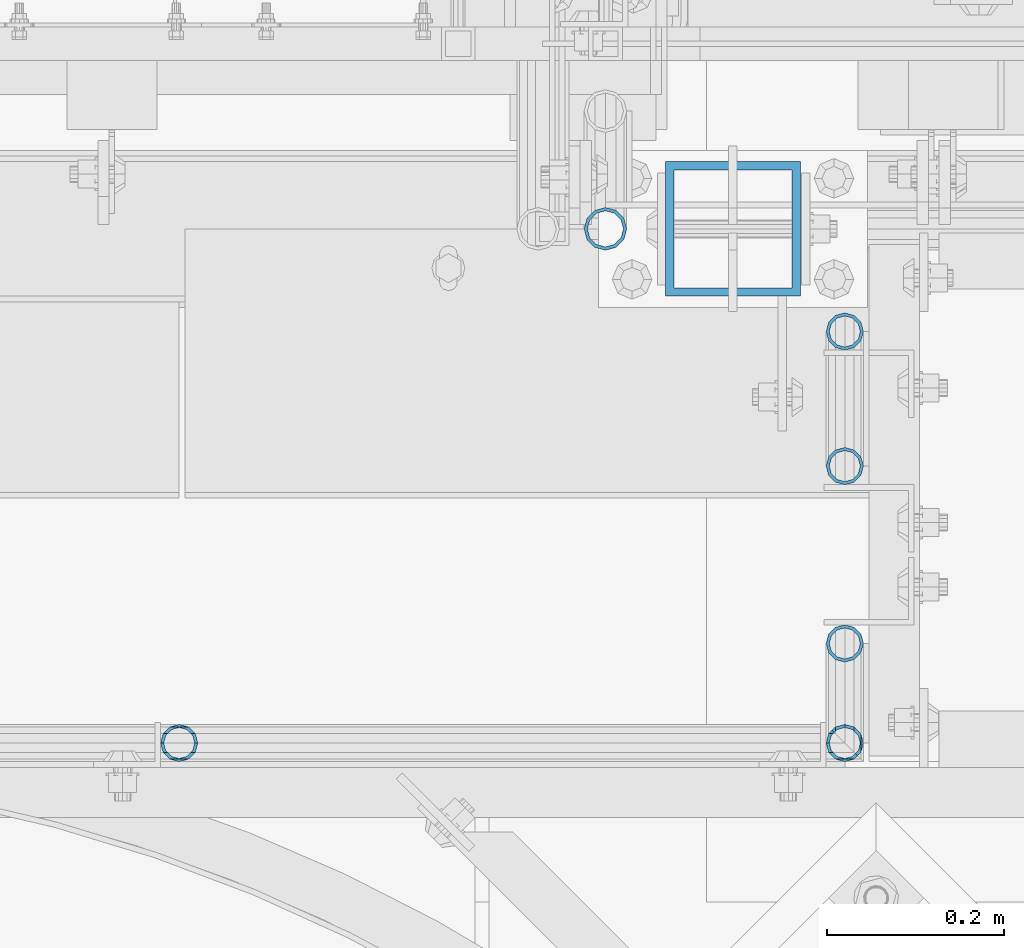
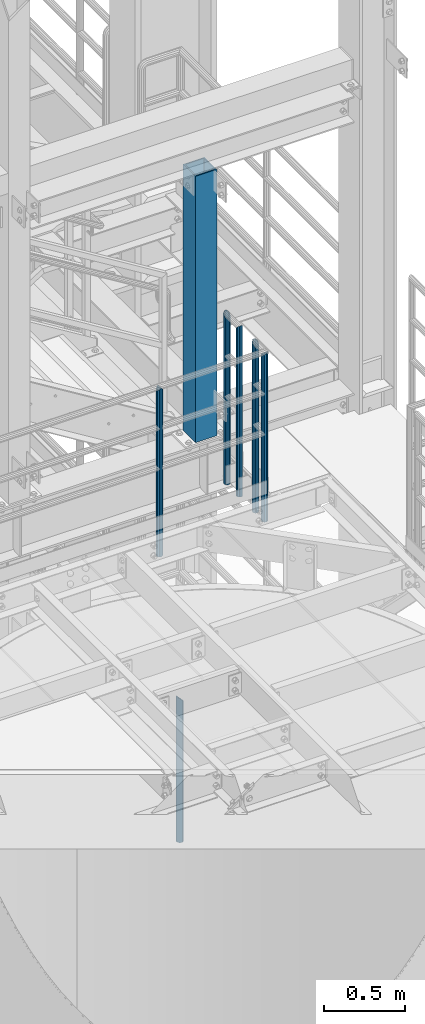
# One storey, part 584 of 1876: 7 columns, 4 elements without a shape of their own.
"""IFC2X3 building model written with IfcOpenShell, lengths in millimetres."""

from ifc_helpers import new_model, si_unit, frame, origin_with_axes, place, context, subcontext, project, spatial, faceted_brep, material, type_object, element, aggregate, save


model = new_model("IFC2X3")

# Units and contexts
model_context = context("Model", 3, precision=1e-05, world=origin_with_axes())
body_context = subcontext(model_context, "Body", "Model", "MODEL_VIEW")
ifc_project = project(units=[si_unit("LENGTHUNIT", "METRE", prefix="MILLI"), si_unit("AREAUNIT", "SQUARE_METRE"), si_unit("VOLUMEUNIT", "CUBIC_METRE"), si_unit("MASSUNIT", "GRAM", prefix="KILO"), si_unit("TIMEUNIT", "SECOND"), si_unit("PLANEANGLEUNIT", "RADIAN"), si_unit("SOLIDANGLEUNIT", "STERADIAN"), si_unit("THERMODYNAMICTEMPERATUREUNIT", "DEGREE_CELSIUS"), si_unit("LUMINOUSINTENSITYUNIT", "LUMEN")], contexts=[model_context])

# Site, building, storey
site_placement = place(None, origin_with_axes())
site = spatial("IfcSite", under=ifc_project, at=site_placement, CompositionType="ELEMENT")
building_placement = place(site_placement, origin_with_axes())
building = spatial("IfcBuilding", under=site, at=building_placement, Name="Undefined", CompositionType="ELEMENT")
storey_placement = place(building_placement, origin_with_axes())
storey = spatial("IfcBuildingStorey", under=building, at=storey_placement, Name="Undefined", CompositionType="ELEMENT", Elevation=0.0)

# Assembly, columns
assembly_1_placement = place(storey_placement, origin_with_axes())
assembly_1 = element("IfcElementAssembly", 1, at=assembly_1_placement, inside=storey, Name="RAIL", AssemblyPlace="NOTDEFINED", PredefinedType="RIGID_FRAME")
ifc_material_1 = material()
column_type_1 = type_object("IfcColumnType", Name="PIPE1-1/4STD", PredefinedType="NOTDEFINED")
column_1_placement = place(assembly_1_placement, frame((6544.818, -7380.60115429563, 7813.675), z_axis=(0.0, 1.0, 0.0), x_axis=(0.0, 0.0, 1.0)))
column_1 = element("IfcColumn", 2, at=column_1_placement, type_object=column_type_1, material=ifc_material_1, Name="POST", ObjectType="PIPE1-1/4STD", context=body_context, shape_type="Brep", body=[
    faceted_brep([(0.0, -17.5259999999998, 0.0), (0.0, -15.1779612267264, 8.76300000000083), (1267.58699999999, -15.1779612267264, 8.76299999999992), (1276.35000231344, -17.5259999999998, 0.0), (0.0, -8.76299999999992, 15.1779612267255), (1261.17203877327, -8.76299999999992, 15.1779612267264), (0.0, 0.0, 17.5259999999998), (1258.82399999999, 0.0, 17.5259999999998), (0.0, 8.76299999999992, 15.1779612267255), (1261.17203877327, 8.76299999999992, 15.1779612267264), (0.0, 15.1779612267264, 8.76300000000083), (1267.58699999999, 15.1779612267264, 8.76299999999992), (0.0, 17.5259999999998, 0.0), (1276.34999768657, 17.5259999999998, 0.0), (0.0, 15.1779612267264, -8.76300000000083), (1285.11299999999, 15.1779612267264, -8.76299999999992), (0.0, 8.76299999999992, -15.1779612267255), (1291.52796122672, 8.76299999999992, -15.1779612267264), (0.0, 0.0, -17.5259999999998), (1293.87599999999, 0.0, -17.5259999999998), (0.0, -8.76299999999992, -15.1779612267255), (1291.52796122672, -8.76299999999992, -15.1779612267264), (0.0, -15.1779612267264, -8.76300000000083), (1285.11299999999, -15.1779612267264, -8.76299999999992), (9.09494701772928e-13, -21.0820000000003, 0.0), (0.0, -18.2575475625836, -10.5409999999993), (1286.89099999999, -18.2575475625836, -10.5410000000002), (1276.35000278283, -21.0820000000003, 0.0), (0.0, -10.5410000000002, -18.2575475625836), (1294.60754756258, -10.5410000000002, -18.2575475625836), (-4.28826751885936e-09, 0.0, -21.0820000000003), (1297.43199999999, 0.0, -21.0820000000003), (0.0, 10.5410000000002, -18.2575475625836), (1294.60754756258, 10.5410000000002, -18.2575475625836), (0.0, 18.2575475625836, -10.5409999999993), (1286.89099999999, 18.2575475625836, -10.5410000000002), (9.09494701772928e-13, 21.0820000000003, 0.0), (1276.35, 21.0820000000003, 0.0), (0.0, 18.2575475625836, 10.5409999999993), (1265.809, 18.2575475625836, 10.5410000000002), (0.0, 10.5410000000002, 18.2575475625836), (1258.09245243742, 10.5410000000002, 18.2575475625836), (0.0, 0.0, 21.0820000000003), (1255.268, 0.0, 21.0820000000003), (0.0, -10.5410000000002, 18.2575475625836), (1258.09245243742, -10.5410000000002, 18.2575475625836), (0.0, -18.2575475625836, 10.5409999999993), (1265.809, -18.2575475625836, 10.5410000000002)], [[[0, 1, 2, 3]], [[1, 4, 5, 2]], [[4, 6, 7, 5]], [[6, 8, 9, 7]], [[8, 10, 11, 9]], [[10, 12, 13, 11]], [[12, 14, 15, 13]], [[14, 16, 17, 15]], [[16, 18, 19, 17]], [[18, 20, 21, 19]], [[20, 22, 23, 21]], [[22, 0, 3, 23]], [[24, 25, 26, 27]], [[25, 28, 29, 26]], [[28, 30, 31, 29]], [[30, 32, 33, 31]], [[32, 34, 35, 33]], [[34, 36, 37, 35]], [[36, 38, 39, 37]], [[38, 40, 41, 39]], [[40, 42, 43, 41]], [[42, 44, 45, 43]], [[44, 46, 47, 45]], [[46, 24, 27, 47]], [[29, 31, 33, 35, 37, 39, 41, 43, 45, 47, 27, 26], [5, 7, 9, 11, 13, 15, 17, 19, 21, 23, 3, 2]], [[46, 44, 42, 40, 38, 36, 34, 32, 30, 28, 25, 24], [22, 20, 18, 16, 14, 12, 10, 8, 6, 4, 1, 0]]]),
])
column_2_placement = place(assembly_1_placement, frame((6544.818, -7228.20115429563, 7813.675), z_axis=(0.0, 1.0, 0.0), x_axis=(0.0, 0.0, 1.0)))
column_2 = element("IfcColumn", 3, at=column_2_placement, type_object=column_type_1, material=ifc_material_1, Name="POST", ObjectType="PIPE1-1/4STD", context=body_context, shape_type="Brep", body=[
    faceted_brep([(0.0, -17.5259999999998, 0.0), (0.0, -15.1779612267264, 8.76300000000083), (1285.11300200349, -15.1779612267264, 8.76299999999992), (1276.35000231344, -17.5259999999998, 0.0), (0.0, -8.76299999999992, 15.1779612267255), (1291.52796238344, -8.76299999999992, 15.1779612267264), (0.0, 0.0, 17.5259999999998), (1293.876, 0.0, 17.5259999999998), (0.0, 8.76299999999992, 15.1779612267255), (1291.52796007001, 8.76299999999992, 15.1779612267264), (0.0, 15.1779612267264, 8.76300000000083), (1285.11299799651, 15.1779612267264, 8.76299999999992), (0.0, 17.5259999999998, 0.0), (1276.34999768657, 17.5259999999998, 0.0), (0.0, 15.1779612267264, -8.76300000000083), (1267.58699799651, 15.1779612267264, -8.76299999999992), (0.0, 8.76299999999992, -15.1779612267255), (1261.17203761656, 8.76299999999992, -15.1779612267264), (0.0, 0.0, -17.5259999999998), (1258.824, 0.0, -17.5259999999998), (0.0, -8.76299999999992, -15.1779612267255), (1261.17203992999, -8.76299999999992, -15.1779612267264), (0.0, -15.1779612267264, -8.76300000000083), (1267.58700200349, -15.1779612267264, -8.76299999999992), (9.09494701772928e-13, -21.0820000000003, 0.0), (0.0, -18.2575475625836, -10.5409999999993), (1265.809, -18.2575475625836, -10.5410000000002), (1276.35000278283, -21.0820000000003, 0.0), (0.0, -10.5410000000002, -18.2575475625836), (1258.09245243742, -10.5410000000002, -18.2575475625836), (-4.28826751885936e-09, 0.0, -21.0820000000003), (1255.268, 0.0, -21.0820000000003), (0.0, 10.5410000000002, -18.2575475625836), (1258.09245243742, 10.5410000000002, -18.2575475625836), (0.0, 18.2575475625836, -10.5409999999993), (1265.809, 18.2575475625836, -10.5410000000002), (9.09494701772928e-13, 21.0820000000003, 0.0), (1276.35, 21.0820000000003, 0.0), (0.0, 18.2575475625836, 10.5409999999993), (1286.89099759001, 18.2575475625836, 10.5410000000002), (0.0, 10.5410000000002, 18.2575475625836), (1294.60754617117, 10.5410000000002, 18.2575475625836), (0.0, 0.0, 21.0820000000003), (1297.432, 0.0, 21.0820000000003), (0.0, -10.5410000000002, 18.2575475625836), (1294.607548954, -10.5410000000002, 18.2575475625836), (0.0, -18.2575475625836, 10.5409999999993), (1286.89100241, -18.2575475625836, 10.5410000000002)], [[[0, 1, 2, 3]], [[1, 4, 5, 2]], [[4, 6, 7, 5]], [[6, 8, 9, 7]], [[8, 10, 11, 9]], [[10, 12, 13, 11]], [[12, 14, 15, 13]], [[14, 16, 17, 15]], [[16, 18, 19, 17]], [[18, 20, 21, 19]], [[20, 22, 23, 21]], [[22, 0, 3, 23]], [[24, 25, 26, 27]], [[25, 28, 29, 26]], [[28, 30, 31, 29]], [[30, 32, 33, 31]], [[32, 34, 35, 33]], [[34, 36, 37, 35]], [[36, 38, 39, 37]], [[38, 40, 41, 39]], [[40, 42, 43, 41]], [[42, 44, 45, 43]], [[44, 46, 47, 45]], [[46, 24, 27, 47]], [[29, 31, 33, 35, 37, 39, 41, 43, 45, 47, 27, 26], [5, 7, 9, 11, 13, 15, 17, 19, 21, 23, 3, 2]], [[46, 44, 42, 40, 38, 36, 34, 32, 30, 28, 25, 24], [22, 20, 18, 16, 14, 12, 10, 8, 6, 4, 1, 0]]]),
])
aggregate(assembly_1, [column_1, column_2])

assembly_2_placement = place(storey_placement, origin_with_axes())
assembly_2 = element("IfcElementAssembly", 4, at=assembly_2_placement, inside=storey, Name="HANDRAIL", AssemblyPlace="NOTDEFINED", PredefinedType="RIGID_FRAME")
column_3_placement = place(assembly_2_placement, frame((6544.818, -7581.41990429563, 7813.675), z_axis=(0.0, 1.0, 0.0), x_axis=(0.0, 0.0, 1.0)))
column_3 = element("IfcColumn", 5, at=column_3_placement, type_object=column_type_1, material=ifc_material_1, Name="POST", ObjectType="PIPE1-1/4STD", context=body_context, shape_type="Brep", body=[
    faceted_brep([(0.0, -17.5259999999998, 0.0), (0.0, -15.1779612267264, 8.76300000000083), (1285.11300200349, -15.1779612267264, 8.76299999999992), (1276.35000231344, -17.5259999999998, 0.0), (0.0, -8.76299999999992, 15.1779612267255), (1291.52796238344, -8.76299999999992, 15.1779612267264), (0.0, 0.0, 17.5259999999998), (1293.876, 0.0, 17.5259999999998), (0.0, 8.76299999999992, 15.1779612267255), (1291.52796007001, 8.76299999999992, 15.1779612267264), (0.0, 15.1779612267264, 8.76300000000083), (1285.11299799651, 15.1779612267264, 8.76299999999992), (0.0, 17.5259999999998, 0.0), (1276.34999768657, 17.5259999999998, 0.0), (0.0, 15.1779612267264, -8.76300000000083), (1267.58699799651, 15.1779612267264, -8.76299999999992), (0.0, 8.76299999999992, -15.1779612267255), (1261.17203761656, 8.76299999999992, -15.1779612267264), (0.0, 0.0, -17.5259999999998), (1258.824, 0.0, -17.5259999999998), (0.0, -8.76299999999992, -15.1779612267255), (1261.17203992999, -8.76299999999992, -15.1779612267264), (0.0, -15.1779612267264, -8.76300000000083), (1267.58700200349, -15.1779612267264, -8.76299999999992), (9.09494701772928e-13, -21.0820000000003, 0.0), (0.0, -18.2575475625836, -10.5409999999993), (1265.809, -18.2575475625836, -10.5410000000002), (1276.35000278283, -21.0820000000003, 0.0), (0.0, -10.5410000000002, -18.2575475625836), (1258.09245243742, -10.5410000000002, -18.2575475625836), (-4.28826751885936e-09, 0.0, -21.0820000000003), (1255.268, 0.0, -21.0820000000003), (0.0, 10.5410000000002, -18.2575475625836), (1258.09245243742, 10.5410000000002, -18.2575475625836), (0.0, 18.2575475625836, -10.5409999999993), (1265.809, 18.2575475625836, -10.5410000000002), (9.09494701772928e-13, 21.0820000000003, 0.0), (1276.35, 21.0820000000003, 0.0), (0.0, 18.2575475625836, 10.5409999999993), (1286.89099759001, 18.2575475625836, 10.5410000000002), (0.0, 10.5410000000002, 18.2575475625836), (1294.60754617117, 10.5410000000002, 18.2575475625836), (0.0, 0.0, 21.0820000000003), (1297.432, 0.0, 21.0820000000003), (0.0, -10.5410000000002, 18.2575475625836), (1294.607548954, -10.5410000000002, 18.2575475625836), (0.0, -18.2575475625836, 10.5409999999993), (1286.89100241, -18.2575475625836, 10.5410000000002)], [[[0, 1, 2, 3]], [[1, 4, 5, 2]], [[4, 6, 7, 5]], [[6, 8, 9, 7]], [[8, 10, 11, 9]], [[10, 12, 13, 11]], [[12, 14, 15, 13]], [[14, 16, 17, 15]], [[16, 18, 19, 17]], [[18, 20, 21, 19]], [[20, 22, 23, 21]], [[22, 0, 3, 23]], [[24, 25, 26, 27]], [[25, 28, 29, 26]], [[28, 30, 31, 29]], [[30, 32, 33, 31]], [[32, 34, 35, 33]], [[34, 36, 37, 35]], [[36, 38, 39, 37]], [[38, 40, 41, 39]], [[40, 42, 43, 41]], [[42, 44, 45, 43]], [[44, 46, 47, 45]], [[46, 24, 27, 47]], [[29, 31, 33, 35, 37, 39, 41, 43, 45, 47, 27, 26], [5, 7, 9, 11, 13, 15, 17, 19, 21, 23, 3, 2]], [[46, 44, 42, 40, 38, 36, 34, 32, 30, 28, 25, 24], [22, 20, 18, 16, 14, 12, 10, 8, 6, 4, 1, 0]]]),
])
column_4_placement = place(assembly_2_placement, frame((6544.818, -7694.13240429563, 7813.675), z_axis=(0.0, 1.0, 0.0), x_axis=(0.0, 0.0, 1.0)))
column_4 = element("IfcColumn", 6, at=column_4_placement, type_object=column_type_1, material=ifc_material_1, Name="POST", ObjectType="PIPE1-1/4STD", context=body_context, shape_type="Brep", body=[
    faceted_brep([(1276.35, 0.0, -21.0820000000003), (1265.809, 10.5410000000002, -18.2575475625836), (1265.809, -10.5410000000002, -18.2575475625836), (1261.95301633583, 14.3969836641645, -14.4015638984183), (1259.5242231679, 11.9681904962363, -11.9727707304901), (1262.72937633681, 8.76299999999992, -15.1779612267255), (1265.07741511008, 0.0, -17.5259999999998), (1262.72937633681, -8.76299999999992, -15.1779612267255), (1258.09245243741, -13.3999612267244, -10.541000000002), (1258.09245243742, -18.2575475625836, -10.5409999999993), (1257.61602877145, -15.1779612267264, -8.76300000000083), (1255.268, -17.5259999999998, 0.0), (1255.268, -21.0820000000003, 0.0), (1257.61604877511, -15.1779612267264, 8.76300000000083), (1258.09245243741, -13.399961226728, 10.5409999999983), (1258.09245243742, -18.2575475625836, 10.5409999999993), (1259.51964293365, -11.9727707304901, 11.9681904962363), (1261.94843610158, -14.4015638984183, 14.3969836641645), (1258.09245243741, -10.5455802342522, 13.3953809924742), (1258.09245243742, -10.5410000000002, 18.2575475625836), (1257.6148115032, -8.76299999999992, 15.1779612267264), (1255.268, 0.0, 17.5259999999998), (1255.268, 0.0, 21.0820000000003), (1257.61726604334, 8.76299999999992, 15.1779612267264), (1258.09245243741, 10.5364197657482, 13.4045414609782), (1258.09245243742, 10.5410000000002, 18.2575475625836), (1276.35, 21.0774197657483, 0.0), (1265.809, 18.2575475625836, 10.5410000000002), (1265.809, 18.2575475625836, -10.5410000000002), (1262.73399389839, 15.1779612267264, 8.76299999999992), (1265.08203267166, 17.5259999999998, 0.0), (1262.73399389839, 15.1779612267264, -8.76299999999992), (0.0, -18.2575475625836, -10.5409999999993), (0.0, -10.5410000000002, -18.2575475625836), (-4.28826751885936e-09, 0.0, -21.0820000000003), (0.0, 10.5410000000002, -18.2575475625836), (0.0, 18.2575475625836, -10.5409999999993), (9.09494701772928e-13, 21.0820000000003, 0.0), (0.0, -18.2575475625836, 10.5409999999993), (9.09494701772928e-13, -21.0820000000003, 0.0), (0.0, -10.5410000000002, 18.2575475625836), (0.0, 0.0, 21.0820000000003), (0.0, 10.5410000000002, 18.2575475625836), (0.0, 18.2575475625836, 10.5409999999993), (0.0, -15.1779612267264, -8.76300000000083), (0.0, -8.76299999999992, -15.1779612267255), (0.0, 0.0, -17.5259999999998), (0.0, 8.76299999999992, -15.1779612267255), (0.0, 15.1779612267264, -8.76300000000083), (0.0, 17.5259999999998, 0.0), (0.0, 15.1779612267264, 8.76300000000083), (0.0, 8.76299999999992, 15.1779612267255), (0.0, 0.0, 17.5259999999998), (0.0, -8.76299999999992, 15.1779612267255), (0.0, -15.1779612267264, 8.76300000000083), (0.0, -17.5259999999998, 0.0)], [[[0, 1, 2]], [[2, 1, 3, 4, 5, 6, 7, 8, 9]], [[9, 8, 10, 11, 12]], [[12, 11, 13, 14, 15]], [[15, 14, 16, 17]], [[17, 16, 18, 19]], [[19, 18, 20, 21, 22]], [[22, 21, 23, 24, 25]], [[26, 27, 28]], [[25, 24, 29, 30, 31, 4, 3, 28, 27]], [[32, 33, 2, 9]], [[33, 34, 0, 2]], [[34, 35, 1, 0]], [[1, 35, 36, 28, 3]], [[36, 37, 26, 28]], [[38, 39, 12, 15]], [[40, 38, 15, 17, 19]], [[41, 40, 19, 22]], [[42, 41, 22, 25]], [[43, 42, 25, 27]], [[37, 43, 27, 26]], [[39, 32, 9, 12]], [[38, 40, 41, 42, 43, 37, 36, 35, 34, 33, 32, 39], [44, 45, 46, 47, 48, 49, 50, 51, 52, 53, 54, 55]], [[50, 49, 30, 29]], [[23, 51, 50, 29, 24]], [[52, 51, 23, 21]], [[53, 52, 21, 20]], [[13, 54, 53, 20, 18, 16, 14]], [[55, 54, 13, 11]], [[44, 55, 11, 10]], [[45, 44, 10, 8, 7]], [[46, 45, 7, 6]], [[47, 46, 6, 5]], [[48, 47, 5, 4, 31]], [[49, 48, 31, 30]]]),
])
column_5_placement = place(assembly_2_placement, frame((5791.20474593762, -7694.13240429563, 7813.675), z_axis=(0.0, 1.0, 0.0), x_axis=(0.0, 0.0, 1.0)))
column_5 = element("IfcColumn", 7, at=column_5_placement, type_object=column_type_1, material=ifc_material_1, Name="POST", ObjectType="PIPE1-1/4STD", context=body_context, shape_type="Brep", body=[
    faceted_brep([(1276.35, 0.0, -21.0820000000003), (1265.809, 10.5410000000002, -18.2575475625836), (1265.809, -10.5410000000002, -18.2575475625836), (1257.61603877328, 15.1779612267264, 8.76299999999992), (1255.268, 17.5259999999998, 0.0), (1255.268, 21.0820000000003, 0.0), (1258.09245243742, 18.2575475625836, 10.5410000000002), (1258.09245243742, 13.3999612267262, 10.5410000000002), (1258.09245243742, 13.3999612267262, -10.5410000000002), (1258.09245243742, 18.2575475625836, -10.5410000000002), (1257.61603877328, 15.1779612267264, -8.76299999999992), (1262.72937633681, 8.76299999999992, -15.1779612267255), (1265.07741511008, 0.0, -17.5259999999998), (1262.72937633681, -8.76299999999992, -15.1779612267255), (1258.09245243741, -13.3999612267244, -10.541000000002), (1258.09245243742, -18.2575475625836, -10.5409999999993), (1257.61602877145, -15.1779612267264, -8.76300000000083), (1255.268, -17.5259999999998, 0.0), (1255.268, -21.0820000000003, 0.0), (1257.61604877511, -15.1779612267264, 8.76300000000083), (1258.09245243741, -13.399961226728, 10.5409999999983), (1258.09245243742, -18.2575475625836, 10.5409999999993), (1276.35, 0.0, 21.0820000000003), (1265.809, -10.5410000000002, 18.2575475625836), (1265.809, 10.5410000000002, 18.2575475625836), (1262.72941366414, -8.76299999999992, 15.1779612267264), (1265.07745243742, 0.0, 17.5259999999998), (1262.72941366414, 8.76299999999992, 15.1779612267264), (0.0, -18.2575475625836, -10.5409999999993), (0.0, -10.5410000000002, -18.2575475625836), (-4.28826751885936e-09, 0.0, -21.0820000000003), (0.0, 10.5410000000002, -18.2575475625836), (0.0, 18.2575475625836, -10.5409999999993), (9.09494701772928e-13, 21.0820000000003, 0.0), (0.0, 18.2575475625836, 10.5409999999993), (0.0, 10.5410000000002, 18.2575475625836), (0.0, 0.0, 21.0820000000003), (0.0, -18.2575475625836, 10.5409999999993), (9.09494701772928e-13, -21.0820000000003, 0.0), (0.0, -10.5410000000002, 18.2575475625836), (0.0, -15.1779612267264, -8.76300000000083), (0.0, -8.76299999999992, -15.1779612267255), (0.0, 0.0, -17.5259999999998), (0.0, 8.76299999999992, -15.1779612267255), (0.0, 15.1779612267264, -8.76300000000083), (0.0, 17.5259999999998, 0.0), (0.0, 15.1779612267264, 8.76300000000083), (0.0, 8.76299999999992, 15.1779612267255), (0.0, 0.0, 17.5259999999998), (0.0, -8.76299999999992, 15.1779612267255), (0.0, -15.1779612267264, 8.76300000000083), (0.0, -17.5259999999998, 0.0)], [[[0, 1, 2]], [[3, 4, 5, 6, 7]], [[8, 9, 5, 4, 10]], [[2, 1, 9, 8, 11, 12, 13, 14, 15]], [[15, 14, 16, 17, 18]], [[18, 17, 19, 20, 21]], [[22, 23, 24]], [[21, 20, 25, 26, 27, 7, 6, 24, 23]], [[28, 29, 2, 15]], [[29, 30, 0, 2]], [[30, 31, 1, 0]], [[31, 32, 9, 1]], [[32, 33, 5, 9]], [[33, 34, 6, 5]], [[34, 35, 24, 6]], [[35, 36, 22, 24]], [[37, 38, 18, 21]], [[39, 37, 21, 23]], [[36, 39, 23, 22]], [[38, 28, 15, 18]], [[37, 39, 36, 35, 34, 33, 32, 31, 30, 29, 28, 38], [40, 41, 42, 43, 44, 45, 46, 47, 48, 49, 50, 51]], [[49, 48, 26, 25]], [[19, 50, 49, 25, 20]], [[51, 50, 19, 17]], [[40, 51, 17, 16]], [[41, 40, 16, 14, 13]], [[42, 41, 13, 12]], [[43, 42, 12, 11]], [[10, 44, 43, 11, 8]], [[45, 44, 10, 4]], [[46, 45, 4, 3]], [[47, 46, 3, 7, 27]], [[48, 47, 27, 26]]]),
])
aggregate(assembly_2, [column_3, column_4, column_5])

# Assembly, column
assembly_3_placement = place(storey_placement, origin_with_axes())
assembly_3 = element("IfcElementAssembly", 8, at=assembly_3_placement, inside=storey, Name="COLUMN", AssemblyPlace="NOTDEFINED", PredefinedType="RIGID_FRAME")
ifc_material_2 = material()
column_type_2 = type_object("IfcColumnType", Name="HSS6X6X3/8", PredefinedType="NOTDEFINED")
column_6_placement = place(assembly_3_placement, frame((6418.2625, -7112.0, 8153.4), z_axis=(-1.0, 0.0, 0.0), x_axis=(0.0, 0.0, 1.0)))
column_6 = element("IfcColumn", 9, at=column_6_placement, type_object=column_type_2, material=ifc_material_2, Name="COLUMN", ObjectType="HSS6X6X3/8", context=body_context, shape_type="Brep", body=[
    faceted_brep([(12.7000000000016, 66.6750000000002, -66.6750000000002), (12.7000000000016, -66.6750000000002, -66.6750000000002), (2028.825, -66.6750000000002, -66.6750000000002), (2028.825, 66.6750000000002, -66.6750000000002), (12.7000000000016, -66.6750000000002, 66.6750000000002), (2028.825, -66.6750000000002, 66.6750000000002), (12.7000000000016, 66.6750000000002, 66.6750000000002), (2028.825, 66.6750000000002, 66.6750000000002), (12.7000000000016, 76.1999999999998, -76.1999999999998), (12.7000000000016, 76.1999999999998, 76.1999999999998), (2028.825, 76.1999999999998, 76.1999999999998), (2028.825, 76.1999999999998, -76.1999999999998), (12.7000000000016, -76.1999999999998, 76.1999999999998), (2028.825, -76.1999999999998, 76.1999999999998), (12.7000000000016, -76.1999999999998, -76.1999999999998), (2028.825, -76.1999999999998, -76.1999999999998)], [[[0, 1, 2, 3]], [[1, 4, 5, 2]], [[4, 6, 7, 5]], [[6, 0, 3, 7]], [[8, 9, 10, 11]], [[9, 12, 13, 10]], [[12, 14, 15, 13]], [[14, 8, 11, 15]], [[13, 15, 11, 10], [5, 7, 3, 2]], [[14, 12, 9, 8], [6, 4, 1, 0]]]),
])
aggregate(assembly_3, [column_6])

assembly_4_placement = place(storey_placement, origin_with_axes())
assembly_4 = element("IfcElementAssembly", 10, at=assembly_4_placement, inside=storey, Name="RAIL", AssemblyPlace="NOTDEFINED", PredefinedType="RIGID_FRAME")
column_type_3 = type_object("IfcColumnType", Name="PIPE1-1/2SCH40", PredefinedType="NOTDEFINED")
column_7_placement = place(assembly_4_placement, frame((6273.80016410903, -7112.0, 5130.79999999999), z_axis=(0.0, 1.0, 0.0), x_axis=(0.0, 0.0, 1.0)))
column_7 = element("IfcColumn", 11, at=column_7_placement, type_object=column_type_3, material=ifc_material_1, Name="POST", ObjectType="PIPE1-1/2SCH40", context=body_context, shape_type="Brep", body=[
    faceted_brep([(0.0, -20.4469999999999, 0.0), (0.0, -17.7076214311803, 10.2235000000001), (1094.03262143118, -17.7076214311804, 10.2235000000001), (1096.772, -20.447, 0.0), (0.0, -10.2235000000001, 17.7076214311801), (1086.5485, -10.2235, 17.7076214311801), (-1.45519152283669e-11, 0.0, 20.4470000000001), (1076.325, 0.0, 20.4470000000001), (0.0, 10.2235000000001, 17.7076214311801), (1066.1015, 10.2235, 17.7076214311801), (0.0, 17.7076214311803, 10.2235000000001), (1058.61737856882, 17.7076214311804, 10.2235000000001), (0.0, 20.4469999999999, 0.0), (1055.878, 20.447, 0.0), (0.0, 17.7076214311803, -10.2235000000001), (1058.61737856882, 17.7076214311804, -10.2235000000001), (0.0, 10.2235000000001, -17.7076214311801), (1066.1015, 10.2235, -17.7076214311801), (-1.45519152283669e-11, 0.0, -20.4470000000001), (1076.325, 0.0, -20.4470000000001), (0.0, -10.2235000000001, -17.7076214311801), (1086.5485, -10.2235, -17.7076214311801), (0.0, -17.7076214311803, -10.2235000000001), (1094.03262143118, -17.7076214311804, -10.2235000000001), (0.0, -24.1299999999992, 0.0), (0.0, -20.8971929933184, -12.0649999999996), (1097.22219299332, -20.8971929933185, -12.0649999999996), (1100.455, -24.13, 0.0), (0.0, -12.0650000000001, -20.8971929933186), (1088.39, -12.065, -20.8971929933186), (-1.45519152283669e-11, 0.0, -24.130000000001), (1076.325, 0.0, -24.1300000000001), (0.0, 12.0650000000001, -20.8971929933186), (1064.26, 12.065, -20.8971929933186), (0.0, 20.8971929933184, -12.0649999999996), (1055.42780700668, 20.8971929933185, -12.0649999999996), (0.0, 24.1299999999992, 0.0), (1052.195, 24.13, 0.0), (0.0, 20.8971929933184, 12.0649999999996), (1055.42780700668, 20.8971929933185, 12.0649999999996), (0.0, 12.0650000000001, 20.8971929933186), (1064.26, 12.065, 20.8971929933186), (-1.45519152283669e-11, 0.0, 24.130000000001), (1076.325, 0.0, 24.1300000000001), (0.0, -12.0650000000001, 20.8971929933186), (1088.39, -12.065, 20.8971929933186), (0.0, -20.8971929933184, 12.0649999999996), (1097.22219299332, -20.8971929933185, 12.0649999999996)], [[[0, 1, 2, 3]], [[1, 4, 5, 2]], [[4, 6, 7, 5]], [[6, 8, 9, 7]], [[8, 10, 11, 9]], [[10, 12, 13, 11]], [[12, 14, 15, 13]], [[14, 16, 17, 15]], [[16, 18, 19, 17]], [[18, 20, 21, 19]], [[20, 22, 23, 21]], [[22, 0, 3, 23]], [[24, 25, 26, 27]], [[25, 28, 29, 26]], [[28, 30, 31, 29]], [[30, 32, 33, 31]], [[32, 34, 35, 33]], [[34, 36, 37, 35]], [[36, 38, 39, 37]], [[38, 40, 41, 39]], [[40, 42, 43, 41]], [[42, 44, 45, 43]], [[44, 46, 47, 45]], [[46, 24, 27, 47]], [[29, 31, 33, 35, 37, 39, 41, 43, 45, 47, 27, 26], [5, 7, 9, 11, 13, 15, 17, 19, 21, 23, 3, 2]], [[46, 44, 42, 40, 38, 36, 34, 32, 30, 28, 25, 24], [22, 20, 18, 16, 14, 12, 10, 8, 6, 4, 1, 0]]]),
])
aggregate(assembly_4, [column_7])

save(model, "model.ifc")
